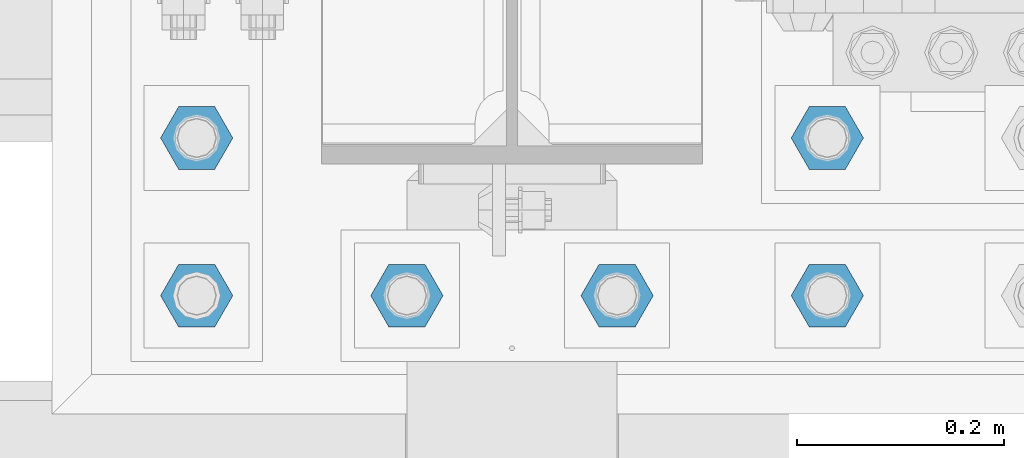
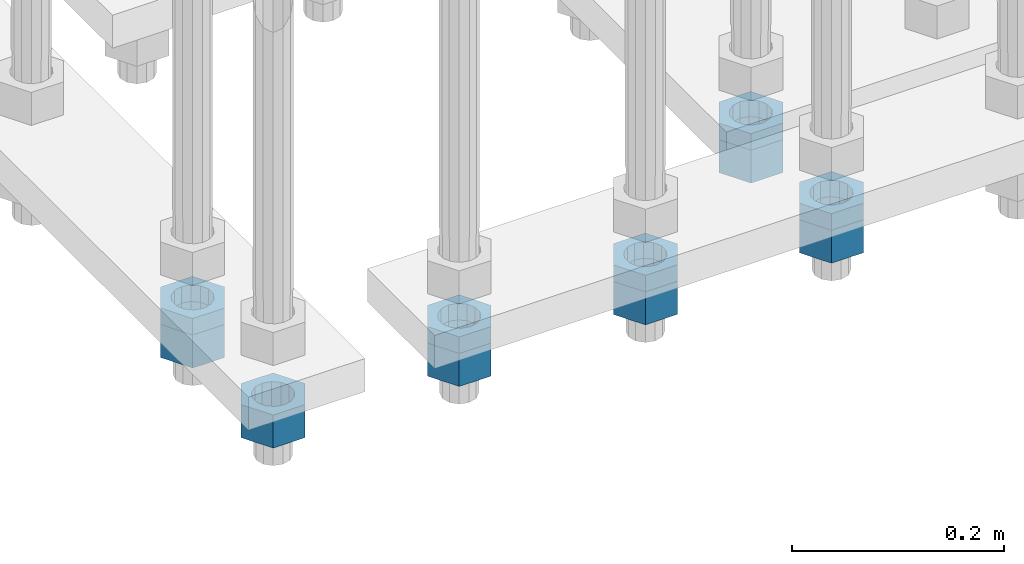
# One storey, part 2790 of 3843: 11 beams, 1 element without a shape of its own.
"""IFC2X3 building model written with IfcOpenShell, lengths in millimetres."""

from ifc_helpers import new_model, si_unit, frame, origin_with_axes, place, context, subcontext, project, spatial, faceted_brep, material, type_object, element, aggregate, save


model = new_model("IFC2X3")

# Units and contexts
model_context = context("Model", 3, precision=1e-05, world=origin_with_axes())
body_context = subcontext(model_context, "Body", "Model", "MODEL_VIEW")
ifc_project = project(units=[si_unit("LENGTHUNIT", "METRE", prefix="MILLI"), si_unit("AREAUNIT", "SQUARE_METRE"), si_unit("VOLUMEUNIT", "CUBIC_METRE"), si_unit("MASSUNIT", "GRAM", prefix="KILO"), si_unit("TIMEUNIT", "SECOND"), si_unit("PLANEANGLEUNIT", "RADIAN"), si_unit("SOLIDANGLEUNIT", "STERADIAN"), si_unit("THERMODYNAMICTEMPERATUREUNIT", "DEGREE_CELSIUS"), si_unit("LUMINOUSINTENSITYUNIT", "LUMEN")], contexts=[model_context])

# Site, building, storey
site_placement = place(None, origin_with_axes())
site = spatial("IfcSite", under=ifc_project, at=site_placement, CompositionType="ELEMENT")
building_placement = place(site_placement, origin_with_axes())
building = spatial("IfcBuilding", under=site, at=building_placement, Name="Undefined", CompositionType="ELEMENT")
storey_placement = place(building_placement, origin_with_axes())
storey = spatial("IfcBuildingStorey", under=building, at=storey_placement, Name="Undefined", CompositionType="ELEMENT", Elevation=0.0)

# Assembly, beams
assembly_placement = place(storey_placement, origin_with_axes())
assembly = element("IfcElementAssembly", 1, at=assembly_placement, inside=storey, Name="TEMPLATE", AssemblyPlace="NOTDEFINED", PredefinedType="RIGID_FRAME")
ifc_material = material(Name="STEEL/A572-50")
beam_type_1 = type_object("IfcBeamType", Name="1-1/2_HEAVY_HEX_NUT", PredefinedType="NOTDEFINED")
beam_1_placement = place(assembly_placement, frame((41757.6, 25311.1, 28746.4500015259), z_axis=(0.0, -1.0, 0.0), x_axis=(0.0, 0.0, -1.0)))
beam_1 = element("IfcBeam", 2, at=beam_1_placement, type_object=beam_type_1, material=ifc_material, Name="NUT", ObjectType="1-1/2_HEAVY_HEX_NUT", context=body_context, shape_type="Brep", body=[
    faceted_brep([(0.0, -34.9199981689453, 0.0), (0.0, -17.4599990844727, -30.25), (38.0999999999985, -17.4599990844727, -30.25), (38.0999999999985, -34.9199981689453, 0.0), (0.0, 17.4599990844727, -30.25), (38.0999999999985, 17.4599990844727, -30.25), (0.0, 34.9199981689453, 0.0), (38.0999999999985, 34.9199981689453, 0.0), (0.0, 17.4599990844727, 30.25), (38.0999999999985, 17.4599990844727, 30.25), (0.0, -17.4599990844727, 30.25), (38.0999999999985, -17.4599990844727, 30.25), (0.0, 0.0, 20.6399993896484), (0.0, 8.9553601105581, 18.5959968835959), (38.0999999999985, 8.9553601105581, 18.5959968835959), (38.0999999999985, 0.0, 20.6399993896484), (0.0, 16.1370013209525, 12.8688291298167), (38.0999999999985, 16.1370013209525, 12.8688291298167), (0.0, 20.1225115123816, 4.59283194104501), (38.0999999999985, 20.1225115123816, 4.59283194104501), (0.0, 20.1225115123816, -4.59283194104501), (38.0999999999985, 20.1225115123816, -4.59283194104501), (0.0, 16.1370013209525, -12.8688291298167), (38.0999999999985, 16.1370013209525, -12.8688291298167), (0.0, 8.9553601105581, -18.5959968835959), (38.0999999999985, 8.9553601105581, -18.5959968835959), (0.0, 0.0, -20.6399993896484), (38.0999999999985, 0.0, -20.6399993896484), (0.0, -8.9553601105581, -18.5959968835959), (38.0999999999985, -8.9553601105581, -18.5959968835959), (0.0, -16.1370013209525, -12.8688291298167), (38.0999999999985, -16.1370013209525, -12.8688291298167), (0.0, -20.1225115123816, -4.59283194104501), (38.0999999999985, -20.1225115123816, -4.59283194104501), (0.0, -20.1225115123816, 4.59283194104501), (38.0999999999985, -20.1225115123816, 4.59283194104501), (0.0, -16.1370013209525, 12.8688291298167), (38.0999999999985, -16.1370013209525, 12.8688291298167), (0.0, -8.9553601105581, 18.5959968835959), (38.0999999999985, -8.9553601105581, 18.5959968835959)], [[[0, 1, 2, 3]], [[1, 4, 5, 2]], [[4, 6, 7, 5]], [[6, 8, 9, 7]], [[8, 10, 11, 9]], [[10, 0, 3, 11]], [[12, 13, 14, 15]], [[13, 16, 17, 14]], [[16, 18, 19, 17]], [[18, 20, 21, 19]], [[20, 22, 23, 21]], [[22, 24, 25, 23]], [[24, 26, 27, 25]], [[26, 28, 29, 27]], [[28, 30, 31, 29]], [[30, 32, 33, 31]], [[32, 34, 35, 33]], [[34, 36, 37, 35]], [[36, 38, 39, 37]], [[38, 12, 15, 39]], [[5, 7, 9, 11, 3, 2], [17, 19, 21, 23, 25, 27, 29, 31, 33, 35, 37, 39, 15, 14]], [[10, 8, 6, 4, 1, 0], [38, 36, 34, 32, 30, 28, 26, 24, 22, 20, 18, 16, 13, 12]]]),
])
beam_2_placement = place(assembly_placement, frame((41960.8, 25311.1, 28746.4500015259), z_axis=(0.0, -1.0, 0.0), x_axis=(0.0, 0.0, -1.0)))
beam_2 = element("IfcBeam", 3, at=beam_2_placement, type_object=beam_type_1, material=ifc_material, Name="NUT", ObjectType="1-1/2_HEAVY_HEX_NUT", context=body_context, shape_type="Brep", body=[
    faceted_brep([(0.0, -34.9199981689453, 0.0), (0.0, -17.4599990844727, -30.25), (38.0999999999985, -17.4599990844727, -30.25), (38.0999999999985, -34.9199981689453, 0.0), (0.0, 17.4599990844727, -30.25), (38.0999999999985, 17.4599990844727, -30.25), (0.0, 34.9199981689453, 0.0), (38.0999999999985, 34.9199981689453, 0.0), (0.0, 17.4599990844727, 30.25), (38.0999999999985, 17.4599990844727, 30.25), (0.0, -17.4599990844727, 30.25), (38.0999999999985, -17.4599990844727, 30.25), (0.0, 0.0, 20.6399993896484), (0.0, 8.9553601105581, 18.5959968835959), (38.0999999999985, 8.9553601105581, 18.5959968835959), (38.0999999999985, 0.0, 20.6399993896484), (0.0, 16.1370013209525, 12.8688291298167), (38.0999999999985, 16.1370013209525, 12.8688291298167), (0.0, 20.1225115123816, 4.59283194104501), (38.0999999999985, 20.1225115123816, 4.59283194104501), (0.0, 20.1225115123816, -4.59283194104501), (38.0999999999985, 20.1225115123816, -4.59283194104501), (0.0, 16.1370013209525, -12.8688291298167), (38.0999999999985, 16.1370013209525, -12.8688291298167), (0.0, 8.9553601105581, -18.5959968835959), (38.0999999999985, 8.9553601105581, -18.5959968835959), (0.0, 0.0, -20.6399993896484), (38.0999999999985, 0.0, -20.6399993896484), (0.0, -8.9553601105581, -18.5959968835959), (38.0999999999985, -8.9553601105581, -18.5959968835959), (0.0, -16.1370013209525, -12.8688291298167), (38.0999999999985, -16.1370013209525, -12.8688291298167), (0.0, -20.1225115123816, -4.59283194104501), (38.0999999999985, -20.1225115123816, -4.59283194104501), (0.0, -20.1225115123816, 4.59283194104501), (38.0999999999985, -20.1225115123816, 4.59283194104501), (0.0, -16.1370013209525, 12.8688291298167), (38.0999999999985, -16.1370013209525, 12.8688291298167), (0.0, -8.9553601105581, 18.5959968835959), (38.0999999999985, -8.9553601105581, 18.5959968835959)], [[[0, 1, 2, 3]], [[1, 4, 5, 2]], [[4, 6, 7, 5]], [[6, 8, 9, 7]], [[8, 10, 11, 9]], [[10, 0, 3, 11]], [[12, 13, 14, 15]], [[13, 16, 17, 14]], [[16, 18, 19, 17]], [[18, 20, 21, 19]], [[20, 22, 23, 21]], [[22, 24, 25, 23]], [[24, 26, 27, 25]], [[26, 28, 29, 27]], [[28, 30, 31, 29]], [[30, 32, 33, 31]], [[32, 34, 35, 33]], [[34, 36, 37, 35]], [[36, 38, 39, 37]], [[38, 12, 15, 39]], [[5, 7, 9, 11, 3, 2], [17, 19, 21, 23, 25, 27, 29, 31, 33, 35, 37, 39, 15, 14]], [[10, 8, 6, 4, 1, 0], [38, 36, 34, 32, 30, 28, 26, 24, 22, 20, 18, 16, 13, 12]]]),
])
beam_3_placement = place(assembly_placement, frame((42164.0, 25311.1, 28746.4500015259), z_axis=(0.0, -1.0, 0.0), x_axis=(0.0, 0.0, -1.0)))
beam_3 = element("IfcBeam", 4, at=beam_3_placement, type_object=beam_type_1, material=ifc_material, Name="NUT", ObjectType="1-1/2_HEAVY_HEX_NUT", context=body_context, shape_type="Brep", body=[
    faceted_brep([(0.0, -34.9199981689453, 0.0), (0.0, -17.4599990844727, -30.25), (38.0999999999985, -17.4599990844727, -30.25), (38.0999999999985, -34.9199981689453, 0.0), (0.0, 17.4599990844727, -30.25), (38.0999999999985, 17.4599990844727, -30.25), (0.0, 34.9199981689453, 0.0), (38.0999999999985, 34.9199981689453, 0.0), (0.0, 17.4599990844727, 30.25), (38.0999999999985, 17.4599990844727, 30.25), (0.0, -17.4599990844727, 30.25), (38.0999999999985, -17.4599990844727, 30.25), (0.0, 0.0, 20.6399993896484), (0.0, 8.9553601105581, 18.5959968835959), (38.0999999999985, 8.9553601105581, 18.5959968835959), (38.0999999999985, 0.0, 20.6399993896484), (0.0, 16.1370013209525, 12.8688291298167), (38.0999999999985, 16.1370013209525, 12.8688291298167), (0.0, 20.1225115123816, 4.59283194104501), (38.0999999999985, 20.1225115123816, 4.59283194104501), (0.0, 20.1225115123816, -4.59283194104501), (38.0999999999985, 20.1225115123816, -4.59283194104501), (0.0, 16.1370013209525, -12.8688291298167), (38.0999999999985, 16.1370013209525, -12.8688291298167), (0.0, 8.9553601105581, -18.5959968835959), (38.0999999999985, 8.9553601105581, -18.5959968835959), (0.0, 0.0, -20.6399993896484), (38.0999999999985, 0.0, -20.6399993896484), (0.0, -8.9553601105581, -18.5959968835959), (38.0999999999985, -8.9553601105581, -18.5959968835959), (0.0, -16.1370013209525, -12.8688291298167), (38.0999999999985, -16.1370013209525, -12.8688291298167), (0.0, -20.1225115123816, -4.59283194104501), (38.0999999999985, -20.1225115123816, -4.59283194104501), (0.0, -20.1225115123816, 4.59283194104501), (38.0999999999985, -20.1225115123816, 4.59283194104501), (0.0, -16.1370013209525, 12.8688291298167), (38.0999999999985, -16.1370013209525, 12.8688291298167), (0.0, -8.9553601105581, 18.5959968835959), (38.0999999999985, -8.9553601105581, 18.5959968835959)], [[[0, 1, 2, 3]], [[1, 4, 5, 2]], [[4, 6, 7, 5]], [[6, 8, 9, 7]], [[8, 10, 11, 9]], [[10, 0, 3, 11]], [[12, 13, 14, 15]], [[13, 16, 17, 14]], [[16, 18, 19, 17]], [[18, 20, 21, 19]], [[20, 22, 23, 21]], [[22, 24, 25, 23]], [[24, 26, 27, 25]], [[26, 28, 29, 27]], [[28, 30, 31, 29]], [[30, 32, 33, 31]], [[32, 34, 35, 33]], [[34, 36, 37, 35]], [[36, 38, 39, 37]], [[38, 12, 15, 39]], [[5, 7, 9, 11, 3, 2], [17, 19, 21, 23, 25, 27, 29, 31, 33, 35, 37, 39, 15, 14]], [[10, 8, 6, 4, 1, 0], [38, 36, 34, 32, 30, 28, 26, 24, 22, 20, 18, 16, 13, 12]]]),
])
beam_4_placement = place(assembly_placement, frame((42367.2, 25311.1, 28746.4500015259), z_axis=(0.0, 1.0, 0.0), x_axis=(0.0, 0.0, -1.0)))
beam_4 = element("IfcBeam", 5, at=beam_4_placement, type_object=beam_type_1, material=ifc_material, Name="NUT", ObjectType="1-1/2_HEAVY_HEX_NUT", context=body_context, shape_type="Brep", body=[
    faceted_brep([(0.0, -34.9199981689453, 0.0), (0.0, -17.4599990844727, -30.25), (38.0999999999985, -17.4599990844727, -30.25), (38.0999999999985, -34.9199981689453, 0.0), (0.0, 17.4599990844727, -30.25), (38.0999999999985, 17.4599990844727, -30.25), (0.0, 34.9199981689453, 0.0), (38.0999999999985, 34.9199981689453, 0.0), (0.0, 17.4599990844727, 30.25), (38.0999999999985, 17.4599990844727, 30.25), (0.0, -17.4599990844727, 30.25), (38.0999999999985, -17.4599990844727, 30.25), (0.0, 0.0, 20.6399993896484), (0.0, 8.9553601105581, 18.5959968835959), (38.0999999999985, 8.9553601105581, 18.5959968835959), (38.0999999999985, 0.0, 20.6399993896484), (0.0, 16.1370013209525, 12.8688291298167), (38.0999999999985, 16.1370013209525, 12.8688291298167), (0.0, 20.1225115123816, 4.59283194104501), (38.0999999999985, 20.1225115123816, 4.59283194104501), (0.0, 20.1225115123816, -4.59283194104501), (38.0999999999985, 20.1225115123816, -4.59283194104501), (0.0, 16.1370013209525, -12.8688291298167), (38.0999999999985, 16.1370013209525, -12.8688291298167), (0.0, 8.9553601105581, -18.5959968835959), (38.0999999999985, 8.9553601105581, -18.5959968835959), (0.0, 0.0, -20.6399993896484), (38.0999999999985, 0.0, -20.6399993896484), (0.0, -8.9553601105581, -18.5959968835959), (38.0999999999985, -8.9553601105581, -18.5959968835959), (0.0, -16.1370013209525, -12.8688291298167), (38.0999999999985, -16.1370013209525, -12.8688291298167), (0.0, -20.1225115123816, -4.59283194104501), (38.0999999999985, -20.1225115123816, -4.59283194104501), (0.0, -20.1225115123816, 4.59283194104501), (38.0999999999985, -20.1225115123816, 4.59283194104501), (0.0, -16.1370013209525, 12.8688291298167), (38.0999999999985, -16.1370013209525, 12.8688291298167), (0.0, -8.9553601105581, 18.5959968835959), (38.0999999999985, -8.9553601105581, 18.5959968835959)], [[[0, 1, 2, 3]], [[1, 4, 5, 2]], [[4, 6, 7, 5]], [[6, 8, 9, 7]], [[8, 10, 11, 9]], [[10, 0, 3, 11]], [[12, 13, 14, 15]], [[13, 16, 17, 14]], [[16, 18, 19, 17]], [[18, 20, 21, 19]], [[20, 22, 23, 21]], [[22, 24, 25, 23]], [[24, 26, 27, 25]], [[26, 28, 29, 27]], [[28, 30, 31, 29]], [[30, 32, 33, 31]], [[32, 34, 35, 33]], [[34, 36, 37, 35]], [[36, 38, 39, 37]], [[38, 12, 15, 39]], [[5, 7, 9, 11, 3, 2], [17, 19, 21, 23, 25, 27, 29, 31, 33, 35, 37, 39, 15, 14]], [[10, 8, 6, 4, 1, 0], [38, 36, 34, 32, 30, 28, 26, 24, 22, 20, 18, 16, 13, 12]]]),
])
beam_5_placement = place(assembly_placement, frame((41757.6, 25463.5, 28746.4500015259), z_axis=(0.0, -1.0, 0.0), x_axis=(0.0, 0.0, -1.0)))
beam_5 = element("IfcBeam", 6, at=beam_5_placement, type_object=beam_type_1, material=ifc_material, Name="NUT", ObjectType="1-1/2_HEAVY_HEX_NUT", context=body_context, shape_type="Brep", body=[
    faceted_brep([(0.0, -34.9199981689453, 0.0), (0.0, -17.4599990844727, -30.25), (38.0999999999985, -17.4599990844727, -30.25), (38.0999999999985, -34.9199981689453, 0.0), (0.0, 17.4599990844727, -30.25), (38.0999999999985, 17.4599990844727, -30.25), (0.0, 34.9199981689453, 0.0), (38.0999999999985, 34.9199981689453, 0.0), (0.0, 17.4599990844727, 30.25), (38.0999999999985, 17.4599990844727, 30.25), (0.0, -17.4599990844727, 30.25), (38.0999999999985, -17.4599990844727, 30.25), (0.0, 0.0, 20.6399993896484), (0.0, 8.9553601105581, 18.5959968835959), (38.0999999999985, 8.9553601105581, 18.5959968835959), (38.0999999999985, 0.0, 20.6399993896484), (0.0, 16.1370013209525, 12.8688291298167), (38.0999999999985, 16.1370013209525, 12.8688291298167), (0.0, 20.1225115123816, 4.59283194104501), (38.0999999999985, 20.1225115123816, 4.59283194104501), (0.0, 20.1225115123816, -4.59283194104501), (38.0999999999985, 20.1225115123816, -4.59283194104501), (0.0, 16.1370013209525, -12.8688291298167), (38.0999999999985, 16.1370013209525, -12.8688291298167), (0.0, 8.9553601105581, -18.5959968835959), (38.0999999999985, 8.9553601105581, -18.5959968835959), (0.0, 0.0, -20.6399993896484), (38.0999999999985, 0.0, -20.6399993896484), (0.0, -8.9553601105581, -18.5959968835959), (38.0999999999985, -8.9553601105581, -18.5959968835959), (0.0, -16.1370013209525, -12.8688291298167), (38.0999999999985, -16.1370013209525, -12.8688291298167), (0.0, -20.1225115123816, -4.59283194104501), (38.0999999999985, -20.1225115123816, -4.59283194104501), (0.0, -20.1225115123816, 4.59283194104501), (38.0999999999985, -20.1225115123816, 4.59283194104501), (0.0, -16.1370013209525, 12.8688291298167), (38.0999999999985, -16.1370013209525, 12.8688291298167), (0.0, -8.9553601105581, 18.5959968835959), (38.0999999999985, -8.9553601105581, 18.5959968835959)], [[[0, 1, 2, 3]], [[1, 4, 5, 2]], [[4, 6, 7, 5]], [[6, 8, 9, 7]], [[8, 10, 11, 9]], [[10, 0, 3, 11]], [[12, 13, 14, 15]], [[13, 16, 17, 14]], [[16, 18, 19, 17]], [[18, 20, 21, 19]], [[20, 22, 23, 21]], [[22, 24, 25, 23]], [[24, 26, 27, 25]], [[26, 28, 29, 27]], [[28, 30, 31, 29]], [[30, 32, 33, 31]], [[32, 34, 35, 33]], [[34, 36, 37, 35]], [[36, 38, 39, 37]], [[38, 12, 15, 39]], [[5, 7, 9, 11, 3, 2], [17, 19, 21, 23, 25, 27, 29, 31, 33, 35, 37, 39, 15, 14]], [[10, 8, 6, 4, 1, 0], [38, 36, 34, 32, 30, 28, 26, 24, 22, 20, 18, 16, 13, 12]]]),
])
beam_6_placement = place(assembly_placement, frame((42367.2, 25463.5, 28746.4500015259), z_axis=(0.0, 1.0, 0.0), x_axis=(0.0, 0.0, -1.0)))
beam_6 = element("IfcBeam", 7, at=beam_6_placement, type_object=beam_type_1, material=ifc_material, Name="NUT", ObjectType="1-1/2_HEAVY_HEX_NUT", context=body_context, shape_type="Brep", body=[
    faceted_brep([(0.0, -34.9199981689453, 0.0), (0.0, -17.4599990844727, -30.25), (38.0999999999985, -17.4599990844727, -30.25), (38.0999999999985, -34.9199981689453, 0.0), (0.0, 17.4599990844727, -30.25), (38.0999999999985, 17.4599990844727, -30.25), (0.0, 34.9199981689453, 0.0), (38.0999999999985, 34.9199981689453, 0.0), (0.0, 17.4599990844727, 30.25), (38.0999999999985, 17.4599990844727, 30.25), (0.0, -17.4599990844727, 30.25), (38.0999999999985, -17.4599990844727, 30.25), (0.0, 0.0, 20.6399993896484), (0.0, 8.9553601105581, 18.5959968835959), (38.0999999999985, 8.9553601105581, 18.5959968835959), (38.0999999999985, 0.0, 20.6399993896484), (0.0, 16.1370013209525, 12.8688291298167), (38.0999999999985, 16.1370013209525, 12.8688291298167), (0.0, 20.1225115123816, 4.59283194104501), (38.0999999999985, 20.1225115123816, 4.59283194104501), (0.0, 20.1225115123816, -4.59283194104501), (38.0999999999985, 20.1225115123816, -4.59283194104501), (0.0, 16.1370013209525, -12.8688291298167), (38.0999999999985, 16.1370013209525, -12.8688291298167), (0.0, 8.9553601105581, -18.5959968835959), (38.0999999999985, 8.9553601105581, -18.5959968835959), (0.0, 0.0, -20.6399993896484), (38.0999999999985, 0.0, -20.6399993896484), (0.0, -8.9553601105581, -18.5959968835959), (38.0999999999985, -8.9553601105581, -18.5959968835959), (0.0, -16.1370013209525, -12.8688291298167), (38.0999999999985, -16.1370013209525, -12.8688291298167), (0.0, -20.1225115123816, -4.59283194104501), (38.0999999999985, -20.1225115123816, -4.59283194104501), (0.0, -20.1225115123816, 4.59283194104501), (38.0999999999985, -20.1225115123816, 4.59283194104501), (0.0, -16.1370013209525, 12.8688291298167), (38.0999999999985, -16.1370013209525, 12.8688291298167), (0.0, -8.9553601105581, 18.5959968835959), (38.0999999999985, -8.9553601105581, 18.5959968835959)], [[[0, 1, 2, 3]], [[1, 4, 5, 2]], [[4, 6, 7, 5]], [[6, 8, 9, 7]], [[8, 10, 11, 9]], [[10, 0, 3, 11]], [[12, 13, 14, 15]], [[13, 16, 17, 14]], [[16, 18, 19, 17]], [[18, 20, 21, 19]], [[20, 22, 23, 21]], [[22, 24, 25, 23]], [[24, 26, 27, 25]], [[26, 28, 29, 27]], [[28, 30, 31, 29]], [[30, 32, 33, 31]], [[32, 34, 35, 33]], [[34, 36, 37, 35]], [[36, 38, 39, 37]], [[38, 12, 15, 39]], [[5, 7, 9, 11, 3, 2], [17, 19, 21, 23, 25, 27, 29, 31, 33, 35, 37, 39, 15, 14]], [[10, 8, 6, 4, 1, 0], [38, 36, 34, 32, 30, 28, 26, 24, 22, 20, 18, 16, 13, 12]]]),
])
beam_type_2 = type_object("IfcBeamType", Name="1-1/2_HALF_NUT", PredefinedType="NOTDEFINED")
beam_7_placement = place(assembly_placement, frame((41960.8, 25311.1, 28765.5000015259), z_axis=(0.0, -1.0, 0.0), x_axis=(0.0, 0.0, -1.0)))
beam_7 = element("IfcBeam", 8, at=beam_7_placement, type_object=beam_type_2, material=ifc_material, Name="NUT", ObjectType="1-1/2_HALF_NUT", context=body_context, shape_type="Brep", body=[
    faceted_brep([(0.0, -34.9199981689453, 0.0), (0.0, -17.4599990844727, -30.25), (19.0500000000029, -17.4599990844727, -30.25), (19.0500000000029, -34.9199981689453, 0.0), (0.0, 17.4599990844727, -30.25), (19.0500000000029, 17.4599990844727, -30.25), (0.0, 34.9199981689453, 0.0), (19.0500000000029, 34.9199981689453, 0.0), (0.0, 17.4599990844727, 30.25), (19.0500000000029, 17.4599990844727, 30.25), (0.0, -17.4599990844727, 30.25), (19.0500000000029, -17.4599990844727, 30.25), (0.0, 0.0, 20.6399993896484), (0.0, 8.9553601105581, 18.5959968835959), (19.0500000000029, 8.95536011056538, 18.5959968835959), (19.0500000000029, 0.0, 20.6399993896484), (0.0, 16.1370013209525, 12.8688291298167), (19.0500000000029, 16.1370013209489, 12.8688291298167), (0.0, 20.1225115123816, 4.59283194104501), (19.0500000000029, 20.1225115123852, 4.59283194104501), (0.0, 20.1225115123816, -4.59283194104501), (19.0500000000029, 20.1225115123852, -4.59283194104501), (0.0, 16.1370013209525, -12.8688291298167), (19.0500000000029, 16.1370013209489, -12.8688291298167), (0.0, 8.9553601105581, -18.5959968835959), (19.0500000000029, 8.95536011056538, -18.5959968835959), (0.0, 0.0, -20.6399993896484), (19.0500000000029, 0.0, -20.6399993896484), (0.0, -8.9553601105581, -18.5959968835959), (19.0500000000029, -8.95536011056538, -18.5959968835959), (0.0, -16.1370013209525, -12.8688291298167), (19.0500000000029, -16.1370013209489, -12.8688291298167), (0.0, -20.1225115123816, -4.59283194104501), (19.0500000000029, -20.1225115123852, -4.59283194104501), (0.0, -20.1225115123816, 4.59283194104501), (19.0500000000029, -20.1225115123852, 4.59283194104501), (0.0, -16.1370013209525, 12.8688291298167), (19.0500000000029, -16.1370013209489, 12.8688291298167), (0.0, -8.9553601105581, 18.5959968835959), (19.0500000000029, -8.95536011056538, 18.5959968835959)], [[[0, 1, 2, 3]], [[1, 4, 5, 2]], [[4, 6, 7, 5]], [[6, 8, 9, 7]], [[8, 10, 11, 9]], [[10, 0, 3, 11]], [[12, 13, 14, 15]], [[13, 16, 17, 14]], [[16, 18, 19, 17]], [[18, 20, 21, 19]], [[20, 22, 23, 21]], [[22, 24, 25, 23]], [[24, 26, 27, 25]], [[26, 28, 29, 27]], [[28, 30, 31, 29]], [[30, 32, 33, 31]], [[32, 34, 35, 33]], [[34, 36, 37, 35]], [[36, 38, 39, 37]], [[38, 12, 15, 39]], [[5, 7, 9, 11, 3, 2], [17, 19, 21, 23, 25, 27, 29, 31, 33, 35, 37, 39, 15, 14]], [[10, 8, 6, 4, 1, 0], [38, 36, 34, 32, 30, 28, 26, 24, 22, 20, 18, 16, 13, 12]]]),
])
beam_8_placement = place(assembly_placement, frame((42164.0, 25311.1, 28765.5000015259), z_axis=(0.0, -1.0, 0.0), x_axis=(0.0, 0.0, -1.0)))
beam_8 = element("IfcBeam", 9, at=beam_8_placement, type_object=beam_type_2, material=ifc_material, Name="NUT", ObjectType="1-1/2_HALF_NUT", context=body_context, shape_type="Brep", body=[
    faceted_brep([(0.0, -34.9199981689453, 0.0), (0.0, -17.4599990844727, -30.25), (19.0500000000029, -17.4599990844727, -30.25), (19.0500000000029, -34.9199981689453, 0.0), (0.0, 17.4599990844727, -30.25), (19.0500000000029, 17.4599990844727, -30.25), (0.0, 34.9199981689453, 0.0), (19.0500000000029, 34.9199981689453, 0.0), (0.0, 17.4599990844727, 30.25), (19.0500000000029, 17.4599990844727, 30.25), (0.0, -17.4599990844727, 30.25), (19.0500000000029, -17.4599990844727, 30.25), (0.0, 0.0, 20.6399993896484), (0.0, 8.9553601105581, 18.5959968835959), (19.0500000000029, 8.95536011056538, 18.5959968835959), (19.0500000000029, 0.0, 20.6399993896484), (0.0, 16.1370013209525, 12.8688291298167), (19.0500000000029, 16.1370013209489, 12.8688291298167), (0.0, 20.1225115123816, 4.59283194104501), (19.0500000000029, 20.1225115123852, 4.59283194104501), (0.0, 20.1225115123816, -4.59283194104501), (19.0500000000029, 20.1225115123852, -4.59283194104501), (0.0, 16.1370013209525, -12.8688291298167), (19.0500000000029, 16.1370013209489, -12.8688291298167), (0.0, 8.9553601105581, -18.5959968835959), (19.0500000000029, 8.95536011056538, -18.5959968835959), (0.0, 0.0, -20.6399993896484), (19.0500000000029, 0.0, -20.6399993896484), (0.0, -8.9553601105581, -18.5959968835959), (19.0500000000029, -8.95536011056538, -18.5959968835959), (0.0, -16.1370013209525, -12.8688291298167), (19.0500000000029, -16.1370013209489, -12.8688291298167), (0.0, -20.1225115123816, -4.59283194104501), (19.0500000000029, -20.1225115123852, -4.59283194104501), (0.0, -20.1225115123816, 4.59283194104501), (19.0500000000029, -20.1225115123852, 4.59283194104501), (0.0, -16.1370013209525, 12.8688291298167), (19.0500000000029, -16.1370013209489, 12.8688291298167), (0.0, -8.9553601105581, 18.5959968835959), (19.0500000000029, -8.95536011056538, 18.5959968835959)], [[[0, 1, 2, 3]], [[1, 4, 5, 2]], [[4, 6, 7, 5]], [[6, 8, 9, 7]], [[8, 10, 11, 9]], [[10, 0, 3, 11]], [[12, 13, 14, 15]], [[13, 16, 17, 14]], [[16, 18, 19, 17]], [[18, 20, 21, 19]], [[20, 22, 23, 21]], [[22, 24, 25, 23]], [[24, 26, 27, 25]], [[26, 28, 29, 27]], [[28, 30, 31, 29]], [[30, 32, 33, 31]], [[32, 34, 35, 33]], [[34, 36, 37, 35]], [[36, 38, 39, 37]], [[38, 12, 15, 39]], [[5, 7, 9, 11, 3, 2], [17, 19, 21, 23, 25, 27, 29, 31, 33, 35, 37, 39, 15, 14]], [[10, 8, 6, 4, 1, 0], [38, 36, 34, 32, 30, 28, 26, 24, 22, 20, 18, 16, 13, 12]]]),
])
beam_9_placement = place(assembly_placement, frame((42367.2, 25311.1, 28765.5000015259), z_axis=(0.0, 1.0, 0.0), x_axis=(0.0, 0.0, -1.0)))
beam_9 = element("IfcBeam", 10, at=beam_9_placement, type_object=beam_type_2, material=ifc_material, Name="NUT", ObjectType="1-1/2_HALF_NUT", context=body_context, shape_type="Brep", body=[
    faceted_brep([(0.0, -34.9199981689453, 0.0), (0.0, -17.4599990844727, -30.25), (19.0500000000029, -17.4599990844727, -30.25), (19.0500000000029, -34.9199981689453, 0.0), (0.0, 17.4599990844727, -30.25), (19.0500000000029, 17.4599990844727, -30.25), (0.0, 34.9199981689453, 0.0), (19.0500000000029, 34.9199981689453, 0.0), (0.0, 17.4599990844727, 30.25), (19.0500000000029, 17.4599990844727, 30.25), (0.0, -17.4599990844727, 30.25), (19.0500000000029, -17.4599990844727, 30.25), (0.0, 0.0, 20.6399993896484), (0.0, 8.9553601105581, 18.5959968835959), (19.0500000000029, 8.95536011056538, 18.5959968835959), (19.0500000000029, 0.0, 20.6399993896484), (0.0, 16.1370013209525, 12.8688291298167), (19.0500000000029, 16.1370013209489, 12.8688291298167), (0.0, 20.1225115123816, 4.59283194104501), (19.0500000000029, 20.1225115123852, 4.59283194104501), (0.0, 20.1225115123816, -4.59283194104501), (19.0500000000029, 20.1225115123852, -4.59283194104501), (0.0, 16.1370013209525, -12.8688291298167), (19.0500000000029, 16.1370013209489, -12.8688291298167), (0.0, 8.9553601105581, -18.5959968835959), (19.0500000000029, 8.95536011056538, -18.5959968835959), (0.0, 0.0, -20.6399993896484), (19.0500000000029, 0.0, -20.6399993896484), (0.0, -8.9553601105581, -18.5959968835959), (19.0500000000029, -8.95536011056538, -18.5959968835959), (0.0, -16.1370013209525, -12.8688291298167), (19.0500000000029, -16.1370013209489, -12.8688291298167), (0.0, -20.1225115123816, -4.59283194104501), (19.0500000000029, -20.1225115123852, -4.59283194104501), (0.0, -20.1225115123816, 4.59283194104501), (19.0500000000029, -20.1225115123852, 4.59283194104501), (0.0, -16.1370013209525, 12.8688291298167), (19.0500000000029, -16.1370013209489, 12.8688291298167), (0.0, -8.9553601105581, 18.5959968835959), (19.0500000000029, -8.95536011056538, 18.5959968835959)], [[[0, 1, 2, 3]], [[1, 4, 5, 2]], [[4, 6, 7, 5]], [[6, 8, 9, 7]], [[8, 10, 11, 9]], [[10, 0, 3, 11]], [[12, 13, 14, 15]], [[13, 16, 17, 14]], [[16, 18, 19, 17]], [[18, 20, 21, 19]], [[20, 22, 23, 21]], [[22, 24, 25, 23]], [[24, 26, 27, 25]], [[26, 28, 29, 27]], [[28, 30, 31, 29]], [[30, 32, 33, 31]], [[32, 34, 35, 33]], [[34, 36, 37, 35]], [[36, 38, 39, 37]], [[38, 12, 15, 39]], [[5, 7, 9, 11, 3, 2], [17, 19, 21, 23, 25, 27, 29, 31, 33, 35, 37, 39, 15, 14]], [[10, 8, 6, 4, 1, 0], [38, 36, 34, 32, 30, 28, 26, 24, 22, 20, 18, 16, 13, 12]]]),
])
beam_10_placement = place(assembly_placement, frame((41757.6, 25463.5, 28765.5000015259), z_axis=(0.0, -1.0, 0.0), x_axis=(0.0, 0.0, -1.0)))
beam_10 = element("IfcBeam", 11, at=beam_10_placement, type_object=beam_type_2, material=ifc_material, Name="NUT", ObjectType="1-1/2_HALF_NUT", context=body_context, shape_type="Brep", body=[
    faceted_brep([(0.0, -34.9199981689453, 0.0), (0.0, -17.4599990844727, -30.25), (19.0500000000029, -17.4599990844727, -30.25), (19.0500000000029, -34.9199981689453, 0.0), (0.0, 17.4599990844727, -30.25), (19.0500000000029, 17.4599990844727, -30.25), (0.0, 34.9199981689453, 0.0), (19.0500000000029, 34.9199981689453, 0.0), (0.0, 17.4599990844727, 30.25), (19.0500000000029, 17.4599990844727, 30.25), (0.0, -17.4599990844727, 30.25), (19.0500000000029, -17.4599990844727, 30.25), (0.0, 0.0, 20.6399993896484), (0.0, 8.9553601105581, 18.5959968835959), (19.0500000000029, 8.95536011056538, 18.5959968835959), (19.0500000000029, 0.0, 20.6399993896484), (0.0, 16.1370013209525, 12.8688291298167), (19.0500000000029, 16.1370013209489, 12.8688291298167), (0.0, 20.1225115123816, 4.59283194104501), (19.0500000000029, 20.1225115123852, 4.59283194104501), (0.0, 20.1225115123816, -4.59283194104501), (19.0500000000029, 20.1225115123852, -4.59283194104501), (0.0, 16.1370013209525, -12.8688291298167), (19.0500000000029, 16.1370013209489, -12.8688291298167), (0.0, 8.9553601105581, -18.5959968835959), (19.0500000000029, 8.95536011056538, -18.5959968835959), (0.0, 0.0, -20.6399993896484), (19.0500000000029, 0.0, -20.6399993896484), (0.0, -8.9553601105581, -18.5959968835959), (19.0500000000029, -8.95536011056538, -18.5959968835959), (0.0, -16.1370013209525, -12.8688291298167), (19.0500000000029, -16.1370013209489, -12.8688291298167), (0.0, -20.1225115123816, -4.59283194104501), (19.0500000000029, -20.1225115123852, -4.59283194104501), (0.0, -20.1225115123816, 4.59283194104501), (19.0500000000029, -20.1225115123852, 4.59283194104501), (0.0, -16.1370013209525, 12.8688291298167), (19.0500000000029, -16.1370013209489, 12.8688291298167), (0.0, -8.9553601105581, 18.5959968835959), (19.0500000000029, -8.95536011056538, 18.5959968835959)], [[[0, 1, 2, 3]], [[1, 4, 5, 2]], [[4, 6, 7, 5]], [[6, 8, 9, 7]], [[8, 10, 11, 9]], [[10, 0, 3, 11]], [[12, 13, 14, 15]], [[13, 16, 17, 14]], [[16, 18, 19, 17]], [[18, 20, 21, 19]], [[20, 22, 23, 21]], [[22, 24, 25, 23]], [[24, 26, 27, 25]], [[26, 28, 29, 27]], [[28, 30, 31, 29]], [[30, 32, 33, 31]], [[32, 34, 35, 33]], [[34, 36, 37, 35]], [[36, 38, 39, 37]], [[38, 12, 15, 39]], [[5, 7, 9, 11, 3, 2], [17, 19, 21, 23, 25, 27, 29, 31, 33, 35, 37, 39, 15, 14]], [[10, 8, 6, 4, 1, 0], [38, 36, 34, 32, 30, 28, 26, 24, 22, 20, 18, 16, 13, 12]]]),
])
beam_11_placement = place(assembly_placement, frame((42367.2, 25463.5, 28765.5000015259), z_axis=(0.0, 1.0, 0.0), x_axis=(0.0, 0.0, -1.0)))
beam_11 = element("IfcBeam", 12, at=beam_11_placement, type_object=beam_type_2, material=ifc_material, Name="NUT", ObjectType="1-1/2_HALF_NUT", context=body_context, shape_type="Brep", body=[
    faceted_brep([(0.0, -34.9199981689453, 0.0), (0.0, -17.4599990844727, -30.25), (19.0500000000029, -17.4599990844727, -30.25), (19.0500000000029, -34.9199981689453, 0.0), (0.0, 17.4599990844727, -30.25), (19.0500000000029, 17.4599990844727, -30.25), (0.0, 34.9199981689453, 0.0), (19.0500000000029, 34.9199981689453, 0.0), (0.0, 17.4599990844727, 30.25), (19.0500000000029, 17.4599990844727, 30.25), (0.0, -17.4599990844727, 30.25), (19.0500000000029, -17.4599990844727, 30.25), (0.0, 0.0, 20.6399993896484), (0.0, 8.9553601105581, 18.5959968835959), (19.0500000000029, 8.95536011056538, 18.5959968835959), (19.0500000000029, 0.0, 20.6399993896484), (0.0, 16.1370013209525, 12.8688291298167), (19.0500000000029, 16.1370013209489, 12.8688291298167), (0.0, 20.1225115123816, 4.59283194104501), (19.0500000000029, 20.1225115123852, 4.59283194104501), (0.0, 20.1225115123816, -4.59283194104501), (19.0500000000029, 20.1225115123852, -4.59283194104501), (0.0, 16.1370013209525, -12.8688291298167), (19.0500000000029, 16.1370013209489, -12.8688291298167), (0.0, 8.9553601105581, -18.5959968835959), (19.0500000000029, 8.95536011056538, -18.5959968835959), (0.0, 0.0, -20.6399993896484), (19.0500000000029, 0.0, -20.6399993896484), (0.0, -8.9553601105581, -18.5959968835959), (19.0500000000029, -8.95536011056538, -18.5959968835959), (0.0, -16.1370013209525, -12.8688291298167), (19.0500000000029, -16.1370013209489, -12.8688291298167), (0.0, -20.1225115123816, -4.59283194104501), (19.0500000000029, -20.1225115123852, -4.59283194104501), (0.0, -20.1225115123816, 4.59283194104501), (19.0500000000029, -20.1225115123852, 4.59283194104501), (0.0, -16.1370013209525, 12.8688291298167), (19.0500000000029, -16.1370013209489, 12.8688291298167), (0.0, -8.9553601105581, 18.5959968835959), (19.0500000000029, -8.95536011056538, 18.5959968835959)], [[[0, 1, 2, 3]], [[1, 4, 5, 2]], [[4, 6, 7, 5]], [[6, 8, 9, 7]], [[8, 10, 11, 9]], [[10, 0, 3, 11]], [[12, 13, 14, 15]], [[13, 16, 17, 14]], [[16, 18, 19, 17]], [[18, 20, 21, 19]], [[20, 22, 23, 21]], [[22, 24, 25, 23]], [[24, 26, 27, 25]], [[26, 28, 29, 27]], [[28, 30, 31, 29]], [[30, 32, 33, 31]], [[32, 34, 35, 33]], [[34, 36, 37, 35]], [[36, 38, 39, 37]], [[38, 12, 15, 39]], [[5, 7, 9, 11, 3, 2], [17, 19, 21, 23, 25, 27, 29, 31, 33, 35, 37, 39, 15, 14]], [[10, 8, 6, 4, 1, 0], [38, 36, 34, 32, 30, 28, 26, 24, 22, 20, 18, 16, 13, 12]]]),
])
aggregate(assembly, [beam_7, beam_8, beam_9, beam_10, beam_11, beam_1, beam_2, beam_3, beam_4, beam_5, beam_6])

save(model, "model.ifc")
